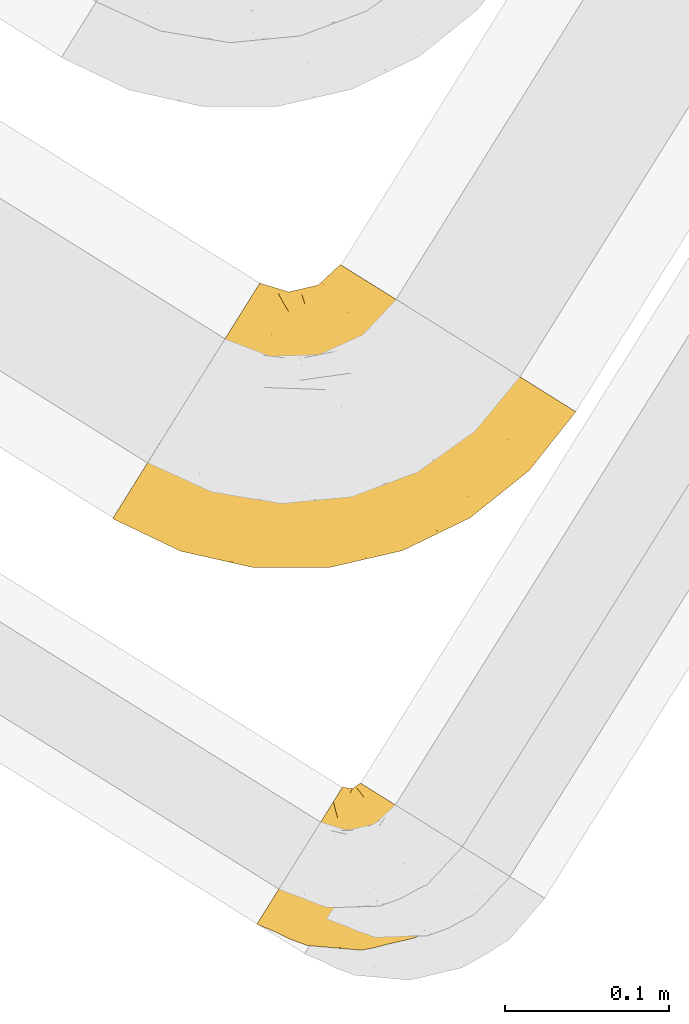
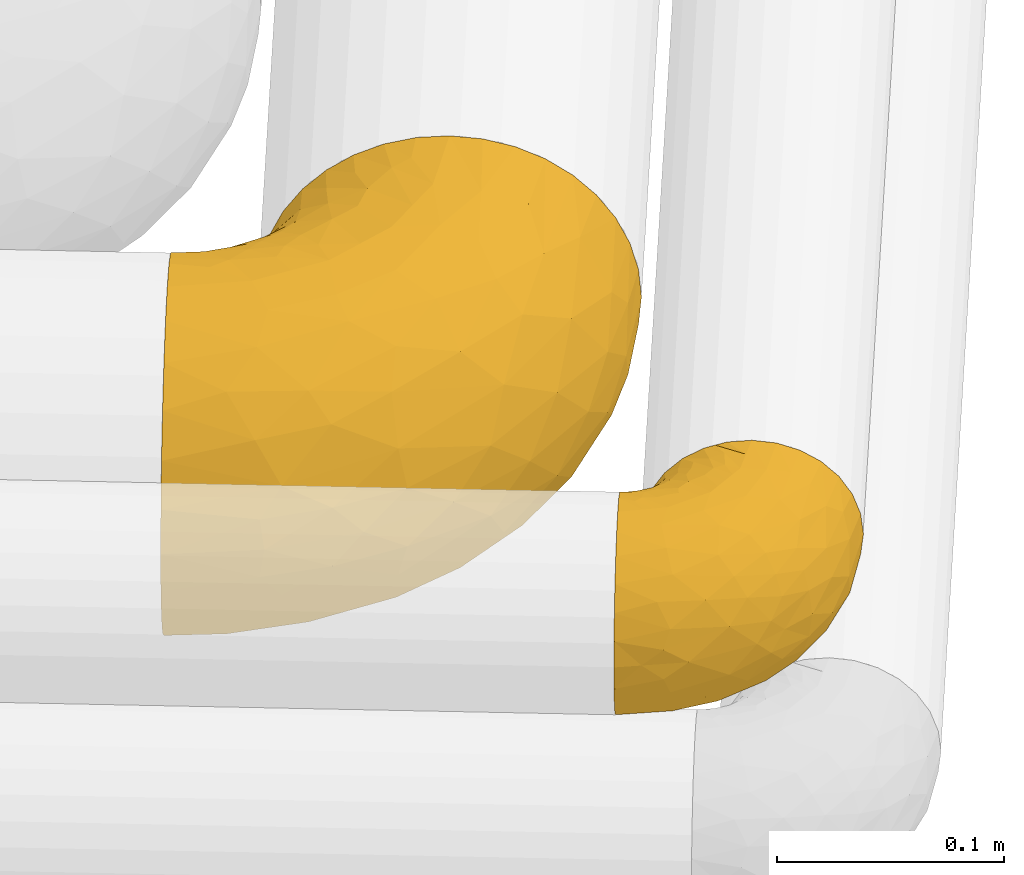
# One storey, part 22 of 93: 2 coverings.
"""IFC2X3 building model written with IfcOpenShell, lengths in millimetres."""

from ifc_helpers import new_model, entity, si_unit, converted_unit, derived_unit, direction, frame, origin, place, context, subcontext, project, spatial, faceted_brep, element, save


model = new_model("IFC2X3")

# Units and contexts
model_context = context("Model", 3, precision=0.01, world=origin(), true_north=direction((6.12303176911189e-17, 1.0)))
body_context = subcontext(model_context, "Body", "Model", "MODEL_VIEW")
ifc_project = project(units=[si_unit("LENGTHUNIT", "METRE", prefix="MILLI"), si_unit("AREAUNIT", "SQUARE_METRE"), si_unit("VOLUMEUNIT", "CUBIC_METRE"), converted_unit("PLANEANGLEUNIT", "DEGREE", entity("IfcRatioMeasure", 0.0174532925199433), si_unit("PLANEANGLEUNIT", "RADIAN"), dimensions=[0, 0, 0, 0, 0, 0, 0]), si_unit("MASSUNIT", "GRAM", prefix="KILO"), derived_unit("MASSDENSITYUNIT", [(si_unit("MASSUNIT", "GRAM", prefix="KILO"), 1), (si_unit("LENGTHUNIT", "METRE"), -3)]), derived_unit("MOMENTOFINERTIAUNIT", [(si_unit("LENGTHUNIT", "METRE"), 4)]), si_unit("TIMEUNIT", "SECOND"), si_unit("FREQUENCYUNIT", "HERTZ"), si_unit("THERMODYNAMICTEMPERATUREUNIT", "DEGREE_CELSIUS"), derived_unit("THERMALTRANSMITTANCEUNIT", [(si_unit("MASSUNIT", "GRAM", prefix="KILO"), 1), (si_unit("THERMODYNAMICTEMPERATUREUNIT", "KELVIN"), -1), (si_unit("TIMEUNIT", "SECOND"), -3)]), derived_unit("VOLUMETRICFLOWRATEUNIT", [(si_unit("LENGTHUNIT", "METRE"), 3), (si_unit("TIMEUNIT", "SECOND"), -1)]), derived_unit("MASSFLOWRATEUNIT", [(si_unit("MASSUNIT", "GRAM", prefix="KILO"), 1), (si_unit("TIMEUNIT", "SECOND"), -1)]), derived_unit("ROTATIONALFREQUENCYUNIT", [(si_unit("TIMEUNIT", "SECOND"), -1)]), si_unit("ELECTRICCURRENTUNIT", "AMPERE"), si_unit("ELECTRICVOLTAGEUNIT", "VOLT"), si_unit("POWERUNIT", "WATT"), si_unit("FORCEUNIT", "NEWTON", prefix="KILO"), si_unit("ILLUMINANCEUNIT", "LUX"), si_unit("LUMINOUSFLUXUNIT", "LUMEN"), si_unit("LUMINOUSINTENSITYUNIT", "CANDELA"), derived_unit("USERDEFINED", [(si_unit("MASSUNIT", "GRAM", prefix="KILO"), -1), (si_unit("LENGTHUNIT", "METRE"), -2), (si_unit("TIMEUNIT", "SECOND"), 3), (si_unit("LUMINOUSFLUXUNIT", "LUMEN"), 1)]), derived_unit("LINEARVELOCITYUNIT", [(si_unit("LENGTHUNIT", "METRE"), 1), (si_unit("TIMEUNIT", "SECOND"), -1)]), si_unit("PRESSUREUNIT", "PASCAL"), derived_unit("USERDEFINED", [(si_unit("LENGTHUNIT", "METRE"), -2), (si_unit("MASSUNIT", "GRAM", prefix="KILO"), 1), (si_unit("TIMEUNIT", "SECOND"), -2)]), derived_unit("LINEARFORCEUNIT", [(si_unit("MASSUNIT", "GRAM", prefix="KILO"), 1), (si_unit("LENGTHUNIT", "METRE"), 1), (si_unit("TIMEUNIT", "SECOND"), -2), (si_unit("LENGTHUNIT", "METRE"), -1)]), derived_unit("PLANARFORCEUNIT", [(si_unit("MASSUNIT", "GRAM", prefix="KILO"), 1), (si_unit("LENGTHUNIT", "METRE"), 1), (si_unit("TIMEUNIT", "SECOND"), -2), (si_unit("LENGTHUNIT", "METRE"), -2)])], contexts=[model_context])

# Site, building, storey
site_placement = place(None, origin())
site = spatial("IfcSite", under=ifc_project, at=site_placement, CompositionType="ELEMENT")
building_placement = place(site_placement, origin())
building = spatial("IfcBuilding", under=site, at=building_placement, CompositionType="ELEMENT")
storey_placement = place(building_placement, frame((0.0, 0.0, -4200.0)))
storey = spatial("IfcBuildingStorey", under=building, at=storey_placement, CompositionType="ELEMENT", Elevation=-4200.0)

# Coverings
covering_1_placement = place(storey_placement, frame((13227.4, 6556.88, 2914.66)))
element("IfcCovering", 1, at=covering_1_placement, inside=storey, Name=":ADSK_", ObjectType=":ADSK_", PredefinedType="INSULATION", context=body_context, shape_type="Brep", body=[
    faceted_brep([(236.24, 125.96, 165.51), (247.56, 118.89, 159.28), (257.79, 112.49, 150.83), (266.62, 106.97, 140.42), (273.79, 102.5, 128.36), (279.07, 99.2, 115.01), (282.3, 97.18, 100.78), (283.39, 96.5, 86.11), (282.3, 97.18, 71.43), (279.07, 99.2, 57.2), (273.79, 102.5, 43.85), (266.62, 106.97, 31.79), (257.79, 112.49, 21.37), (247.56, 118.88, 12.92), (236.24, 125.96, 6.7), (224.18, 133.5, 2.89), (211.73, 141.27, 1.6), (199.29, 149.05, 2.89), (187.22, 156.59, 6.7), (175.9, 163.67, 12.92), (165.67, 170.06, 21.37), (156.84, 175.58, 31.78), (149.67, 180.05, 43.85), (144.39, 183.35, 57.2), (141.16, 185.37, 71.42), (140.07, 186.05, 86.1), (141.16, 185.37, 100.77), (144.39, 183.35, 115.0), (149.67, 180.05, 128.35), (156.83, 175.58, 140.42), (165.67, 170.06, 150.83), (175.9, 163.67, 159.28), (187.22, 156.59, 165.5), (193.25, 152.82, 167.41), (199.28, 149.05, 169.32), (211.73, 141.28, 170.6), (224.17, 133.5, 169.32), (89.63, 172.32, 64.23), (85.15, 165.16, 43.85), (78.04, 153.77, 26.34), (68.77, 138.93, 12.92), (57.97, 121.64, 4.47), (53.51, 114.52, 3.37), (46.38, 103.1, 1.6), (34.79, 84.55, 4.47), (23.99, 67.27, 12.92), (14.71, 52.43, 26.34), (7.6, 41.04, 43.85), (3.12, 33.88, 64.23), (1.6, 31.44, 86.1), (3.12, 33.88, 107.97), (7.59, 41.04, 128.35), (14.71, 52.43, 145.85), (23.98, 67.27, 159.27), (34.78, 84.56, 167.72), (46.37, 103.1, 170.6), (53.51, 114.52, 168.82), (57.96, 121.65, 167.72), (63.36, 130.29, 163.5), (68.76, 138.93, 159.27), (78.03, 153.77, 145.85), (85.15, 165.16, 128.35), (89.62, 172.32, 107.97), (91.15, 174.76, 86.1), (42.9, 11.67, 86.1), (87.57, 1.6, 86.1), (73.74, 5.1, 101.81), (41.71, 13.6, 101.53), (52.94, 13.91, 115.32), (152.07, 28.34, 144.07), (122.94, 34.47, 153.56), (112.73, 20.64, 140.98), (133.37, 1.71, 86.1), (109.86, 1.83, 101.79), (63.67, 54.21, 161.76), (191.01, 41.1, 142.72), (216.81, 67.01, 150.75), (185.64, 54.67, 155.51), (242.33, 79.4, 143.1), (155.49, 7.68, 104.95), (177.99, 12.01, 86.1), (198.76, 23.97, 108.35), (42.51, 44.5, 151.11), (46.7, 26.52, 134.54), (250.34, 65.52, 119.09), (237.88, 47.34, 102.35), (262.24, 71.71, 105.31), (77.61, 68.62, 168.19), (141.72, 67.32, 167.91), (154.91, 93.61, 170.6), (136.62, 89.38, 170.6), (118.33, 85.16, 170.6), (187.65, 73.68, 164.12), (152.11, 49.46, 159.98), (175.17, 85.85, 169.13), (187.09, 112.94, 170.6), (171.0, 103.27, 170.6), (109.7, 63.97, 167.97), (99.63, 86.8, 170.6), (80.93, 88.43, 170.6), (219.2, 31.98, 86.11), (218.0, 44.97, 128.7), (222.86, 91.11, 160.39), (76.32, 30.81, 148.22), (107.91, 49.69, 162.92), (169.11, 19.49, 125.82), (254.93, 60.62, 86.11), (204.51, 100.78, 168.05), (201.88, 129.96, 170.6), (194.49, 121.45, 170.6), (108.5, 7.47, 120.0), (80.92, 18.79, 135.81), (70.55, 92.84, 170.6), (60.18, 97.24, 170.6), (119.84, 131.39, 157.07), (131.92, 138.38, 154.23), (118.08, 145.98, 145.04), (95.72, 118.02, 164.31), (100.57, 100.85, 169.15), (109.36, 108.81, 167.14), (82.14, 111.08, 167.64), (71.16, 108.85, 168.98), (94.8, 132.68, 156.82), (81.91, 132.23, 159.34), (144.95, 156.9, 144.96), (130.08, 155.36, 138.16), (87.81, 145.68, 148.65), (126.63, 173.52, 86.1), (116.65, 167.84, 104.93), (130.07, 173.95, 101.3), (96.19, 162.83, 123.52), (140.43, 169.11, 128.62), (102.36, 168.23, 104.01), (118.52, 162.28, 121.86), (108.75, 157.18, 129.84), (168.58, 149.5, 160.87), (157.3, 155.33, 153.11), (163.74, 130.34, 165.79), (189.81, 136.83, 169.24), (129.01, 168.34, 116.6), (152.48, 119.4, 166.96), (147.86, 137.43, 159.05), (138.56, 117.86, 165.68), (179.68, 136.6, 167.57), (137.16, 176.11, 112.04), (93.84, 155.33, 136.39), (120.93, 114.62, 165.43), (106.79, 125.71, 160.11), (120.98, 99.4, 169.44), (108.72, 169.39, 86.1), (98.2, 143.54, 147.97), (116.65, 167.84, 67.27), (120.25, 102.52, 3.36), (123.36, 119.03, 8.36), (133.72, 105.95, 3.6), (130.07, 173.95, 70.9), (110.16, 147.4, 29.26), (122.39, 151.07, 31.85), (119.6, 136.58, 18.75), (102.36, 168.23, 68.18), (140.72, 169.55, 43.83), (145.77, 158.41, 27.99), (109.46, 117.74, 8.26), (88.28, 150.12, 27.75), (99.53, 142.54, 23.54), (89.45, 136.56, 17.03), (134.2, 157.24, 34.05), (71.38, 111.21, 3.69), (81.62, 127.19, 10.28), (85.11, 107.1, 3.79), (95.73, 118.02, 7.89), (106.53, 100.87, 3.12), (187.18, 134.62, 3.06), (129.01, 168.34, 55.6), (118.34, 85.16, 1.6), (137.17, 176.11, 60.15), (134.18, 139.84, 18.43), (201.89, 129.95, 1.6), (194.5, 121.45, 1.6), (70.56, 92.83, 1.6), (60.19, 97.24, 1.6), (157.49, 155.94, 19.33), (166.7, 140.85, 8.95), (103.73, 159.0, 44.79), (163.67, 119.38, 3.77), (176.13, 124.93, 3.18), (149.65, 136.1, 12.0), (146.38, 107.22, 3.09), (136.63, 89.38, 1.6), (187.1, 112.94, 1.6), (117.74, 161.18, 48.4), (138.92, 121.56, 7.81), (171.01, 103.27, 1.6), (154.92, 93.6, 1.6), (80.94, 88.43, 1.6), (99.64, 86.79, 1.6), (141.72, 67.32, 4.29), (108.81, 69.82, 2.95), (185.65, 54.67, 16.69), (222.86, 91.11, 11.82), (216.81, 67.01, 21.45), (109.86, 1.83, 70.42), (73.75, 5.09, 70.39), (108.5, 7.47, 52.2), (77.62, 68.61, 4.01), (107.92, 49.69, 9.27), (152.12, 49.46, 12.23), (63.67, 54.2, 10.43), (191.01, 41.1, 29.48), (152.06, 28.34, 28.13), (41.71, 13.6, 70.67), (204.51, 100.78, 4.16), (198.76, 23.96, 63.86), (155.49, 7.68, 67.26), (169.11, 19.49, 46.38), (52.94, 13.91, 56.88), (217.99, 44.96, 43.5), (42.52, 44.49, 21.08), (76.33, 30.8, 23.98), (80.93, 18.78, 36.39), (46.7, 26.52, 37.66), (242.33, 79.4, 29.1), (175.18, 85.85, 3.07), (187.66, 73.68, 8.09), (122.94, 34.47, 18.64), (112.73, 20.64, 31.21), (250.34, 65.52, 53.11), (237.88, 47.34, 69.86), (262.25, 71.71, 66.9)], [[[0, 1, 2, 3, 4, 5, 6, 7, 8, 9, 10, 11, 12, 13, 14, 15, 16, 17, 18, 19, 20, 21, 22, 23, 24, 25, 26, 27, 28, 29, 30, 31, 32, 33, 34, 35, 36]], [[37, 38, 39, 40, 41, 42, 43, 44, 45, 46, 47, 48, 49, 50, 51, 52, 53, 54, 55, 56, 57, 58, 59, 60, 61, 62, 63]], [[64, 65, 66]], [[67, 49, 64]], [[68, 51, 50]], [[69, 70, 71]], [[72, 73, 65]], [[53, 74, 54]], [[75, 76, 77]], [[65, 73, 66]], [[2, 78, 3]], [[79, 80, 81]], [[52, 82, 53]], [[52, 51, 83]], [[51, 68, 83]], [[84, 85, 86]], [[74, 87, 54]], [[88, 89, 90, 91]], [[92, 93, 77]], [[55, 54, 87]], [[94, 95, 96, 89]], [[92, 88, 93]], [[97, 91, 98, 99]], [[93, 70, 69]], [[81, 80, 100]], [[101, 81, 85]], [[76, 1, 102]], [[74, 103, 104]], [[5, 4, 84]], [[84, 4, 78]], [[80, 79, 72]], [[84, 86, 5]], [[77, 102, 92]], [[3, 78, 4]], [[101, 75, 105]], [[106, 7, 6]], [[100, 106, 85]], [[76, 78, 2]], [[107, 35, 108, 109, 95]], [[107, 95, 94]], [[94, 88, 92]], [[79, 105, 110]], [[71, 103, 111]], [[0, 107, 102]], [[84, 78, 101]], [[97, 99, 87]], [[66, 67, 64]], [[1, 76, 2]], [[0, 102, 1]], [[76, 101, 78]], [[107, 0, 36]], [[81, 100, 85]], [[88, 94, 89]], [[93, 88, 104]], [[107, 94, 92]], [[105, 79, 81]], [[73, 79, 110]], [[101, 105, 81]], [[105, 69, 71]], [[111, 68, 110]], [[82, 83, 103]], [[102, 107, 92]], [[107, 36, 35]], [[74, 53, 82]], [[87, 74, 104]], [[97, 87, 104]], [[87, 99, 112, 113, 55]], [[70, 93, 104]], [[77, 76, 102]], [[86, 106, 6]], [[85, 84, 101]], [[79, 73, 72]], [[66, 110, 68]], [[110, 66, 73]], [[66, 68, 67]], [[68, 50, 67]], [[49, 67, 50]], [[104, 103, 70]], [[71, 70, 103]], [[111, 103, 83]], [[105, 71, 110]], [[68, 111, 83]], [[110, 71, 111]], [[93, 69, 77]], [[75, 77, 69]], [[105, 75, 69]], [[101, 76, 75]], [[106, 86, 85]], [[5, 86, 6]], [[83, 82, 52]], [[74, 82, 103]], [[104, 88, 97]], [[91, 97, 88]], [[114, 115, 116]], [[113, 112, 57, 56, 55]], [[117, 118, 119]], [[120, 121, 99]], [[120, 99, 98]], [[117, 122, 123]], [[124, 125, 115]], [[61, 60, 126]], [[127, 128, 129]], [[115, 125, 116]], [[130, 62, 61]], [[28, 131, 124]], [[132, 63, 62]], [[133, 132, 134]], [[135, 136, 137]], [[138, 108, 34]], [[128, 139, 129]], [[89, 96, 140]], [[140, 141, 142]], [[32, 31, 143]], [[34, 33, 32, 138]], [[29, 124, 136]], [[141, 124, 115]], [[135, 31, 30]], [[116, 125, 133]], [[35, 34, 108]], [[28, 27, 131]], [[124, 141, 136]], [[144, 131, 27]], [[127, 129, 25]], [[139, 144, 129]], [[95, 109, 108, 138]], [[134, 130, 145]], [[28, 124, 29]], [[29, 136, 30]], [[121, 120, 58]], [[27, 26, 144]], [[124, 131, 125]], [[146, 114, 147]], [[115, 114, 142]], [[131, 139, 125]], [[117, 147, 122]], [[125, 139, 133]], [[135, 143, 31]], [[143, 137, 96]], [[142, 90, 89]], [[137, 136, 141]], [[146, 119, 148]], [[115, 142, 141]], [[119, 146, 147]], [[142, 146, 148]], [[141, 140, 137]], [[26, 25, 129]], [[131, 144, 139]], [[136, 135, 30]], [[143, 135, 137]], [[26, 129, 144]], [[128, 127, 149]], [[132, 128, 149]], [[133, 139, 128]], [[63, 132, 149]], [[132, 62, 130]], [[134, 150, 116]], [[119, 147, 117]], [[150, 114, 116]], [[142, 114, 146]], [[114, 150, 147]], [[122, 147, 150]], [[98, 118, 120]], [[148, 119, 91]], [[118, 117, 120]], [[119, 118, 91]], [[91, 118, 98]], [[123, 120, 117]], [[57, 112, 121]], [[91, 90, 148]], [[142, 148, 90]], [[132, 133, 128]], [[133, 134, 116]], [[142, 89, 140]], [[95, 143, 96]], [[150, 126, 122]], [[123, 60, 59]], [[123, 122, 126]], [[120, 123, 59]], [[126, 150, 145]], [[123, 126, 60]], [[140, 96, 137]], [[145, 130, 61]], [[132, 130, 134]], [[126, 145, 61]], [[134, 145, 150]], [[32, 143, 138]], [[95, 138, 143]], [[121, 112, 99]], [[120, 59, 58]], [[57, 121, 58]], [[149, 127, 151]], [[152, 153, 154]], [[127, 155, 151]], [[156, 157, 158]], [[159, 149, 151]], [[159, 63, 149]], [[160, 22, 161]], [[153, 152, 162]], [[163, 164, 165]], [[166, 160, 161]], [[167, 40, 168]], [[169, 170, 171]], [[169, 168, 170]], [[168, 165, 170]], [[172, 19, 18]], [[166, 173, 160]], [[174, 171, 152]], [[24, 175, 155]], [[176, 158, 157]], [[17, 16, 177, 178]], [[41, 167, 179]], [[160, 23, 22]], [[175, 24, 23]], [[180, 43, 42, 41, 179]], [[20, 181, 21]], [[182, 20, 19]], [[21, 181, 161]], [[21, 161, 22]], [[38, 37, 183]], [[184, 182, 185]], [[186, 161, 181]], [[172, 18, 17]], [[187, 188, 154]], [[161, 176, 166]], [[185, 19, 172]], [[178, 189, 172]], [[178, 172, 17]], [[151, 173, 190]], [[164, 163, 183]], [[155, 25, 24]], [[166, 176, 157]], [[175, 160, 173]], [[153, 176, 191]], [[20, 182, 181]], [[186, 181, 182]], [[185, 182, 19]], [[172, 189, 185]], [[189, 192, 185]], [[187, 184, 193]], [[184, 185, 192]], [[160, 175, 23]], [[155, 175, 173]], [[155, 173, 151]], [[155, 127, 25]], [[173, 166, 190]], [[159, 183, 37]], [[193, 184, 192]], [[186, 182, 184]], [[159, 151, 190]], [[63, 159, 37]], [[176, 161, 186]], [[166, 157, 190]], [[191, 176, 186]], [[158, 176, 153]], [[187, 186, 184]], [[191, 154, 153]], [[156, 190, 157]], [[188, 152, 154]], [[159, 190, 183]], [[162, 158, 153]], [[156, 158, 164]], [[164, 183, 156]], [[190, 156, 183]], [[187, 154, 191]], [[152, 188, 174]], [[171, 170, 162]], [[152, 171, 162]], [[167, 169, 194]], [[169, 195, 194]], [[169, 167, 168]], [[174, 195, 171]], [[169, 171, 195]], [[165, 162, 170]], [[158, 162, 164]], [[187, 191, 186]], [[188, 187, 193]], [[40, 167, 41]], [[40, 39, 168]], [[165, 164, 162]], [[168, 39, 165]], [[163, 165, 39]], [[39, 38, 163]], [[183, 163, 38]], [[167, 194, 179]], [[196, 197, 174]], [[198, 199, 200]], [[201, 202, 203]], [[204, 43, 180, 179, 194]], [[205, 196, 206]], [[204, 205, 207]], [[204, 197, 205]], [[196, 174, 188, 193]], [[198, 208, 209]], [[65, 201, 72]], [[49, 48, 210]], [[211, 189, 178, 177, 16]], [[212, 213, 214]], [[48, 47, 215]], [[214, 216, 212]], [[217, 207, 218]], [[217, 46, 45]], [[210, 215, 202]], [[199, 13, 200]], [[219, 215, 220]], [[213, 80, 72]], [[221, 12, 11]], [[222, 193, 192, 189]], [[199, 223, 211]], [[16, 15, 211]], [[212, 100, 80]], [[216, 200, 221]], [[199, 211, 14]], [[14, 13, 199]], [[206, 196, 223]], [[12, 221, 200]], [[218, 224, 225]], [[222, 196, 193]], [[13, 12, 200]], [[221, 11, 10]], [[10, 226, 221]], [[80, 213, 212]], [[226, 227, 216]], [[212, 216, 227]], [[226, 10, 9]], [[228, 106, 227]], [[100, 227, 106]], [[7, 106, 8]], [[47, 220, 215]], [[228, 9, 8]], [[216, 221, 226]], [[223, 198, 206]], [[44, 207, 45]], [[206, 224, 205]], [[223, 222, 211]], [[47, 46, 220]], [[64, 210, 202]], [[196, 222, 223]], [[201, 213, 72]], [[203, 225, 214]], [[203, 214, 213]], [[214, 209, 208]], [[217, 220, 46]], [[218, 225, 219]], [[189, 211, 222]], [[211, 15, 14]], [[44, 43, 204]], [[218, 207, 205]], [[44, 204, 207]], [[197, 194, 195, 174]], [[223, 199, 198]], [[224, 206, 209]], [[212, 227, 100]], [[228, 227, 226]], [[202, 201, 65]], [[213, 201, 203]], [[64, 202, 65]], [[203, 202, 215]], [[49, 210, 64]], [[48, 215, 210]], [[225, 224, 209]], [[218, 205, 224]], [[214, 225, 209]], [[218, 219, 220]], [[225, 203, 219]], [[215, 219, 203]], [[208, 198, 200]], [[209, 206, 198]], [[200, 216, 208]], [[214, 208, 216]], [[9, 228, 226]], [[106, 228, 8]], [[207, 217, 45]], [[220, 217, 218]], [[205, 197, 196]], [[194, 197, 204]]]),
])
covering_2_placement = place(storey_placement, frame((13315.17, 6324.17, 3008.06)))
element("IfcCovering", 2, at=covering_2_placement, inside=storey, Name=":ADSK_", ObjectType=":ADSK_", PredefinedType="INSULATION", context=body_context, shape_type="Brep", body=[
    faceted_brep([(115.47, 71.48, 98.66), (124.28, 65.98, 95.02), (132.18, 61.04, 89.17), (138.78, 56.92, 81.38), (143.74, 53.81, 72.06), (146.82, 51.89, 61.68), (147.87, 51.24, 50.75), (146.82, 51.89, 39.8), (143.74, 53.82, 29.41), (138.77, 56.92, 20.09), (132.17, 61.05, 12.31), (124.27, 65.98, 6.46), (115.46, 71.49, 2.83), (106.19, 77.28, 1.6), (101.35, 80.3, 2.24), (96.91, 83.08, 2.83), (92.5, 85.83, 4.65), (88.1, 88.59, 6.47), (80.19, 93.52, 12.32), (73.59, 97.65, 20.11), (68.63, 100.75, 29.43), (65.55, 102.67, 39.81), (64.51, 103.33, 50.75), (65.55, 102.67, 61.69), (68.64, 100.75, 72.08), (73.6, 97.64, 81.4), (80.2, 93.52, 89.18), (88.11, 88.58, 95.03), (92.51, 85.83, 96.85), (96.92, 83.07, 98.66), (101.35, 80.3, 99.25), (103.77, 78.79, 99.57), (106.19, 77.28, 99.9), (52.8, 99.41, 38.02), (50.2, 95.25, 26.17), (48.13, 91.93, 21.08), (46.06, 88.62, 15.99), (43.36, 84.31, 12.09), (40.66, 79.99, 8.18), (37.52, 74.96, 5.73), (34.38, 69.94, 3.27), (30.68, 64.01, 2.35), (29.16, 61.58, 1.97), (27.64, 59.15, 1.6), (20.9, 48.36, 3.27), (14.62, 38.31, 8.18), (9.22, 29.68, 15.99), (5.08, 23.05, 26.17), (2.48, 18.89, 38.02), (1.6, 17.47, 50.75), (2.48, 18.89, 63.47), (5.08, 23.05, 75.32), (9.22, 29.68, 85.5), (14.62, 38.31, 93.31), (20.9, 48.36, 98.22), (27.64, 59.15, 99.9), (30.68, 64.01, 99.14), (34.38, 69.94, 98.22), (37.52, 74.96, 95.77), (40.66, 79.99, 93.31), (43.36, 84.31, 89.4), (46.06, 88.62, 85.5), (48.13, 91.93, 80.41), (50.2, 95.25, 75.32), (52.8, 99.41, 63.47), (53.69, 100.83, 50.75), (73.31, 3.23, 59.31), (63.34, 6.85, 73.08), (52.09, 3.24, 63.72), (32.17, 4.49, 50.75), (21.61, 8.39, 58.64), (12.86, 12.69, 50.75), (43.87, 9.77, 76.74), (25.69, 9.49, 67.68), (23.01, 16.67, 78.92), (98.31, 38.75, 94.31), (101.46, 55.97, 98.76), (83.87, 43.54, 98.4), (36.32, 31.21, 94.57), (56.63, 20.8, 89.91), (63.92, 32.34, 96.32), (40.28, 42.43, 98.78), (48.44, 51.27, 99.9), (43.21, 53.25, 99.9), (37.98, 55.23, 99.9), (35.39, 56.21, 99.9), (32.81, 57.19, 99.9), (33.49, 21.01, 87.31), (112.01, 52.64, 95.61), (112.46, 17.59, 60.43), (130.37, 32.99, 65.24), (112.5, 22.68, 72.87), (90.95, 61.08, 99.9), (85.88, 58.8, 99.9), (80.81, 56.51, 99.9), (75.74, 54.23, 99.9), (70.67, 51.95, 99.9), (118.64, 47.08, 90.65), (96.67, 10.4, 63.14), (74.9, 25.36, 91.89), (131.15, 40.05, 75.25), (139.84, 42.0, 50.75), (59.94, 12.73, 82.18), (78.9, 17.76, 85.08), (80.37, 11.5, 76.93), (97.61, 9.07, 50.75), (81.43, 5.33, 50.75), (121.38, 38.11, 83.02), (104.29, 75.27, 99.9), (102.4, 73.26, 99.9), (98.61, 69.23, 99.9), (94.78, 65.16, 99.9), (103.3, 29.76, 87.13), (95.69, 19.42, 80.85), (61.66, 42.17, 99.17), (126.08, 26.17, 50.75), (65.11, 51.78, 99.9), (59.55, 51.61, 99.9), (54.0, 51.44, 99.9), (65.25, 1.6, 50.75), (81.05, 6.96, 67.61), (96.01, 13.76, 72.25), (111.85, 17.62, 50.75), (48.71, 3.04, 50.75), (91.72, 76.09, 98.69), (38.92, 63.66, 99.01), (48.91, 61.7, 98.79), (43.4, 65.35, 98.29), (64.06, 98.2, 68.51), (66.59, 94.88, 76.82), (81.93, 68.86, 98.54), (86.96, 67.63, 99.3), (52.95, 87.67, 83.57), (50.78, 81.71, 89.47), (56.25, 92.88, 75.76), (58.26, 85.87, 84.86), (62.6, 93.51, 75.89), (58.48, 97.61, 64.77), (66.65, 80.31, 90.83), (71.97, 75.63, 94.62), (72.35, 83.63, 90.37), (47.07, 80.5, 91.18), (48.73, 71.84, 95.55), (75.48, 88.78, 88.65), (69.69, 90.26, 84.11), (61.83, 77.85, 91.75), (85.19, 78.29, 96.86), (59.61, 99.84, 50.75), (62.4, 100.25, 58.97), (76.09, 66.51, 98.37), (65.46, 88.2, 83.91), (68.04, 66.83, 97.52), (54.09, 61.15, 98.76), (54.18, 71.52, 95.26), (61.38, 64.0, 98.04), (56.26, 79.22, 90.65), (80.2, 83.52, 93.51), (76.45, 79.07, 94.16), (58.74, 59.29, 99.1), (56.24, 92.88, 25.73), (56.25, 79.23, 10.84), (52.93, 87.67, 17.92), (58.24, 85.89, 16.64), (65.43, 97.88, 30.44), (81.93, 68.85, 2.95), (86.96, 67.64, 2.19), (85.88, 58.8, 1.6), (85.18, 78.3, 4.63), (69.68, 90.26, 17.39), (37.98, 55.23, 1.6), (32.81, 57.19, 1.6), (30.23, 58.17, 1.6), (75.45, 88.78, 12.86), (72.33, 83.63, 11.13), (43.4, 65.35, 3.2), (48.73, 71.84, 5.94), (47.07, 80.5, 10.31), (80.18, 83.55, 8.0), (76.44, 79.08, 7.34), (38.92, 63.66, 2.48), (54.09, 61.15, 2.73), (48.97, 61.41, 2.64), (98.61, 69.23, 1.6), (91.71, 76.09, 2.8), (58.47, 97.61, 36.71), (43.21, 53.25, 1.6), (48.44, 51.27, 1.6), (62.49, 99.34, 38.59), (102.4, 73.26, 1.6), (100.51, 71.24, 1.6), (80.81, 56.51, 1.6), (76.09, 66.51, 3.12), (65.45, 88.21, 17.59), (75.74, 54.23, 1.6), (68.01, 66.86, 3.98), (71.96, 75.62, 6.87), (61.39, 64.01, 3.45), (61.81, 77.88, 9.76), (94.78, 65.16, 1.6), (90.95, 61.08, 1.6), (62.6, 93.51, 25.62), (66.64, 80.32, 10.67), (58.74, 59.29, 2.39), (59.55, 51.61, 1.6), (54.18, 71.52, 6.23), (50.78, 81.7, 12.02), (54.0, 51.44, 1.6), (65.11, 51.78, 1.6), (70.67, 51.95, 1.6), (61.75, 41.76, 2.4), (21.61, 8.39, 42.85), (33.49, 21.01, 14.18), (56.28, 20.84, 11.56), (59.9, 12.76, 19.27), (43.88, 9.76, 24.75), (63.39, 6.88, 28.37), (112.31, 52.74, 5.95), (101.55, 55.68, 2.79), (40.28, 42.43, 2.71), (52.09, 3.24, 37.78), (25.69, 9.49, 33.81), (23.02, 16.67, 22.57), (36.32, 31.21, 6.92), (112.5, 22.69, 28.61), (130.36, 32.99, 36.24), (112.45, 17.59, 41.05), (80.47, 11.53, 24.55), (81.05, 6.96, 33.88), (98.8, 39.2, 7.11), (73.31, 3.23, 42.18), (121.37, 38.11, 18.46), (118.63, 47.09, 10.84), (95.81, 19.43, 20.69), (96.03, 13.75, 29.27), (83.88, 43.5, 3.1), (81.13, 27.58, 9.18), (96.63, 10.38, 38.38), (131.14, 40.05, 26.23), (103.13, 29.68, 14.34), (64.07, 31.65, 5.46), (78.9, 17.77, 16.39)], [[[0, 1, 2, 3, 4, 5, 6, 7, 8, 9, 10, 11, 12, 13, 14, 15, 16, 17, 18, 19, 20, 21, 22, 23, 24, 25, 26, 27, 28, 29, 30, 31, 32]], [[33, 34, 35, 36, 37, 38, 39, 40, 41, 42, 43, 44, 45, 46, 47, 48, 49, 50, 51, 52, 53, 54, 55, 56, 57, 58, 59, 60, 61, 62, 63, 64, 65]], [[66, 67, 68]], [[69, 70, 71]], [[68, 72, 73]], [[73, 72, 74]], [[75, 76, 77]], [[78, 79, 80]], [[51, 50, 73]], [[81, 82, 83, 84, 85, 86, 55]], [[52, 87, 53]], [[74, 52, 51]], [[1, 0, 88]], [[89, 90, 91]], [[77, 92, 93, 94, 95, 96]], [[55, 54, 81]], [[78, 53, 87]], [[4, 90, 5]], [[88, 76, 75]], [[97, 2, 1]], [[89, 91, 98]], [[99, 80, 79]], [[90, 4, 100]], [[74, 87, 52]], [[100, 4, 3]], [[90, 101, 5]], [[79, 102, 103]], [[102, 67, 104]], [[105, 98, 106]], [[107, 3, 2]], [[76, 32, 108, 109, 110, 111, 92]], [[107, 112, 113]], [[114, 77, 96]], [[89, 115, 90]], [[114, 96, 116, 117, 118, 82]], [[75, 97, 88]], [[119, 66, 68]], [[50, 71, 70]], [[100, 91, 90]], [[99, 77, 80]], [[102, 104, 103]], [[97, 107, 2]], [[80, 81, 78]], [[107, 97, 112]], [[68, 73, 70]], [[66, 98, 120]], [[78, 81, 54]], [[114, 81, 80]], [[53, 78, 54]], [[78, 87, 79]], [[102, 87, 72]], [[79, 103, 99]], [[3, 107, 100]], [[91, 100, 107]], [[88, 97, 1]], [[112, 97, 75]], [[99, 112, 75]], [[103, 104, 113]], [[91, 121, 98]], [[89, 105, 122, 115]], [[101, 90, 115]], [[101, 6, 5]], [[88, 0, 76]], [[32, 76, 0]], [[92, 77, 76]], [[73, 74, 51]], [[87, 74, 72]], [[81, 114, 82]], [[77, 114, 80]], [[87, 102, 79]], [[67, 102, 72]], [[68, 67, 72]], [[67, 120, 104]], [[120, 121, 104]], [[104, 121, 113]], [[121, 120, 98]], [[91, 107, 113]], [[91, 113, 121]], [[103, 113, 112]], [[66, 119, 106]], [[105, 89, 98]], [[68, 69, 123, 119]], [[98, 66, 106]], [[66, 120, 67]], [[50, 49, 71]], [[50, 70, 73]], [[112, 99, 103]], [[77, 99, 75]], [[69, 68, 70]], [[28, 124, 110]], [[84, 83, 125]], [[126, 82, 118]], [[59, 58, 127]], [[24, 128, 129]], [[130, 93, 131]], [[132, 62, 133]], [[134, 135, 136]], [[137, 65, 64]], [[64, 134, 137]], [[138, 139, 140]], [[111, 110, 124, 92]], [[134, 136, 137]], [[134, 64, 63]], [[141, 60, 142]], [[125, 58, 57]], [[143, 144, 140]], [[143, 25, 144]], [[127, 83, 82]], [[27, 124, 28]], [[108, 32, 31, 30, 29, 110, 109]], [[29, 28, 110]], [[135, 145, 138]], [[27, 146, 124]], [[57, 56, 55, 86, 85, 84]], [[147, 148, 22]], [[23, 22, 148]], [[24, 144, 25]], [[95, 94, 149]], [[23, 128, 24]], [[150, 138, 144]], [[124, 146, 131]], [[127, 58, 125]], [[151, 149, 139]], [[127, 126, 142]], [[142, 59, 127]], [[152, 142, 126]], [[153, 154, 155]], [[153, 133, 141]], [[146, 27, 26]], [[143, 156, 26]], [[157, 149, 130]], [[61, 133, 62]], [[134, 132, 135]], [[148, 128, 23]], [[65, 137, 147]], [[147, 137, 148]], [[128, 137, 136]], [[137, 128, 148]], [[128, 136, 129]], [[150, 129, 136]], [[24, 129, 144]], [[158, 152, 117]], [[152, 118, 117]], [[153, 142, 152]], [[158, 116, 154]], [[145, 151, 138]], [[153, 152, 158]], [[133, 153, 155]], [[133, 155, 132]], [[153, 141, 142]], [[135, 132, 155]], [[134, 63, 132]], [[145, 135, 155]], [[135, 138, 150]], [[155, 154, 145]], [[151, 154, 96]], [[154, 151, 145]], [[149, 94, 130]], [[82, 126, 127]], [[118, 152, 126]], [[151, 96, 95]], [[139, 149, 157]], [[151, 95, 149]], [[93, 92, 131]], [[130, 146, 156]], [[130, 94, 93]], [[84, 125, 57]], [[127, 125, 83]], [[140, 139, 157]], [[151, 139, 138]], [[140, 157, 143]], [[138, 140, 144]], [[156, 143, 157]], [[26, 25, 143]], [[130, 156, 157]], [[146, 26, 156]], [[132, 63, 62]], [[124, 131, 92]], [[130, 131, 146]], [[129, 150, 144]], [[135, 150, 136]], [[60, 141, 61]], [[60, 59, 142]], [[133, 61, 141]], [[116, 96, 154]], [[153, 158, 154]], [[158, 117, 116]], [[34, 33, 159]], [[160, 161, 162]], [[21, 20, 163]], [[164, 165, 166]], [[18, 17, 167]], [[168, 20, 19]], [[42, 41, 40, 169, 170, 171, 43]], [[172, 173, 168]], [[174, 38, 175]], [[37, 36, 176]], [[177, 164, 178]], [[40, 179, 169]], [[180, 181, 175]], [[16, 182, 183]], [[65, 147, 184]], [[185, 174, 186]], [[22, 21, 187]], [[174, 39, 38]], [[14, 13, 188, 189, 182, 15]], [[179, 40, 39]], [[190, 191, 164]], [[192, 163, 168]], [[33, 184, 159]], [[178, 173, 172]], [[193, 194, 191]], [[17, 183, 167]], [[173, 178, 195]], [[196, 197, 194]], [[198, 199, 183, 182]], [[182, 16, 15]], [[17, 16, 183]], [[200, 159, 184]], [[192, 168, 201]], [[187, 163, 200]], [[202, 203, 180]], [[185, 179, 174]], [[160, 204, 205]], [[206, 181, 180]], [[206, 180, 203]], [[199, 165, 183]], [[165, 164, 167]], [[172, 177, 178]], [[200, 192, 162]], [[205, 161, 160]], [[65, 184, 33]], [[163, 187, 21]], [[175, 204, 180]], [[174, 181, 186]], [[204, 196, 202]], [[197, 160, 162]], [[196, 207, 202]], [[37, 176, 175]], [[196, 204, 160]], [[176, 204, 175]], [[205, 35, 161]], [[34, 159, 161]], [[162, 161, 159]], [[200, 162, 159]], [[197, 162, 201]], [[194, 197, 201]], [[196, 160, 197]], [[191, 195, 178]], [[208, 196, 194]], [[186, 181, 206]], [[175, 181, 174]], [[191, 190, 193]], [[193, 208, 194]], [[195, 194, 201]], [[178, 164, 191]], [[168, 163, 20]], [[166, 165, 199]], [[166, 190, 164]], [[187, 200, 184]], [[184, 147, 187]], [[22, 187, 147]], [[174, 179, 39]], [[169, 179, 185]], [[194, 195, 191]], [[173, 201, 168]], [[201, 173, 195]], [[172, 168, 19]], [[19, 18, 172]], [[177, 172, 18]], [[18, 167, 177]], [[164, 177, 167]], [[35, 205, 36]], [[35, 34, 161]], [[183, 165, 167]], [[162, 192, 201]], [[163, 192, 200]], [[175, 38, 37]], [[36, 205, 176]], [[204, 176, 205]], [[204, 202, 180]], [[207, 196, 208]], [[207, 203, 202]], [[209, 186, 206, 203, 207, 208]], [[48, 210, 71]], [[211, 212, 213]], [[214, 213, 215]], [[216, 217, 12]], [[218, 43, 171, 170, 169, 185, 186]], [[219, 220, 214]], [[47, 46, 221]], [[210, 48, 220]], [[211, 222, 212]], [[222, 45, 44]], [[221, 220, 47]], [[47, 220, 48]], [[221, 211, 214]], [[223, 224, 225]], [[211, 46, 45]], [[226, 227, 215]], [[43, 218, 44]], [[217, 216, 228]], [[215, 229, 219]], [[13, 12, 217]], [[224, 8, 7]], [[9, 230, 10]], [[10, 231, 11]], [[232, 223, 233]], [[234, 208, 193, 190, 166, 199]], [[235, 234, 228]], [[222, 44, 218]], [[106, 229, 236]], [[224, 237, 8]], [[231, 238, 228]], [[8, 237, 9]], [[115, 224, 101]], [[239, 234, 235]], [[231, 10, 230]], [[223, 230, 237]], [[224, 7, 101]], [[223, 236, 233]], [[225, 115, 122, 105]], [[216, 11, 231]], [[209, 234, 239]], [[210, 219, 69]], [[219, 214, 215]], [[229, 119, 219]], [[209, 218, 186]], [[239, 212, 222]], [[239, 222, 218]], [[45, 222, 211]], [[235, 212, 239]], [[213, 212, 240]], [[223, 237, 224]], [[230, 9, 237]], [[238, 231, 230]], [[216, 231, 228]], [[232, 230, 223]], [[235, 238, 240]], [[115, 225, 224]], [[233, 236, 227]], [[7, 6, 101]], [[234, 209, 208]], [[218, 209, 239]], [[217, 228, 234]], [[12, 11, 216]], [[234, 199, 217]], [[217, 199, 198, 182, 189, 188, 13]], [[211, 221, 46]], [[220, 221, 214]], [[71, 210, 69]], [[71, 49, 48]], [[219, 210, 220]], [[226, 215, 213]], [[211, 213, 214]], [[226, 213, 240]], [[215, 227, 229]], [[232, 240, 238]], [[233, 227, 226]], [[232, 233, 226]], [[236, 223, 225]], [[240, 232, 226]], [[232, 238, 230]], [[225, 105, 236]], [[236, 105, 106]], [[229, 106, 119]], [[69, 219, 119, 123]], [[236, 229, 227]], [[238, 235, 228]], [[212, 235, 240]]]),
])

save(model, "model.ifc")
